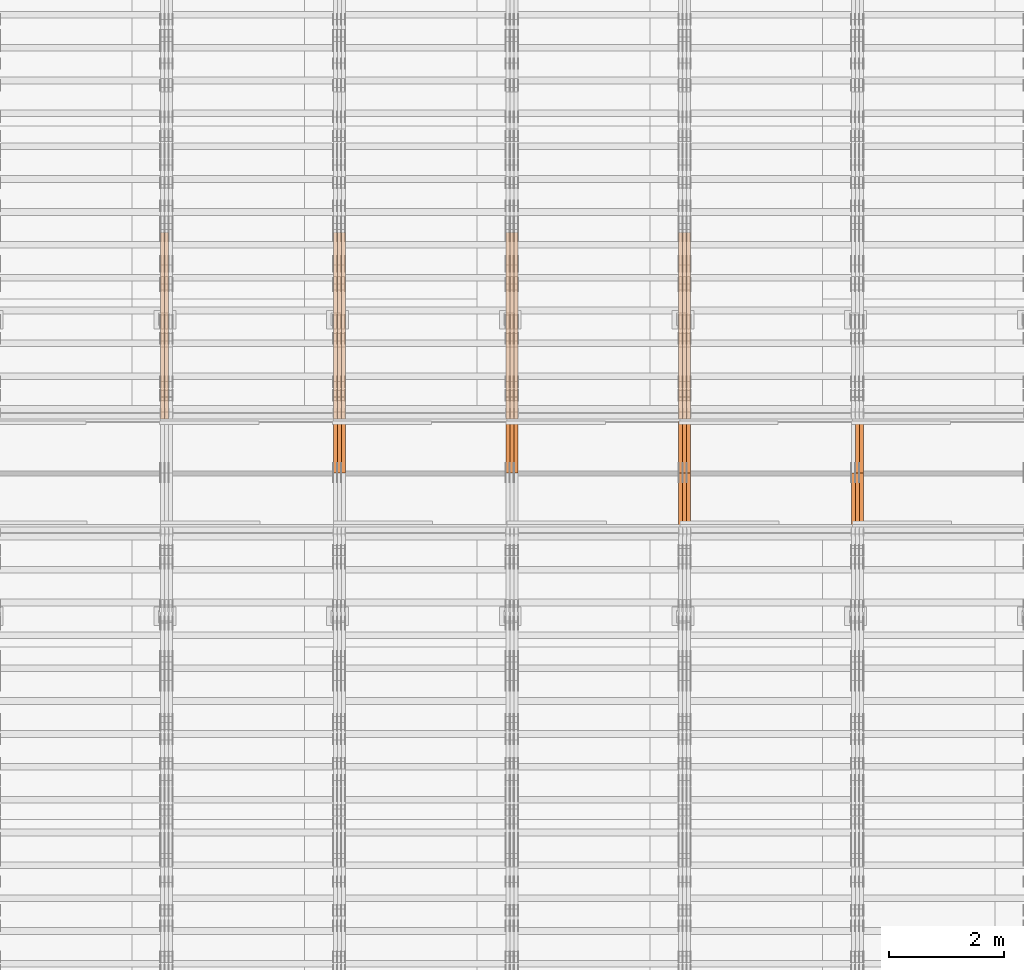
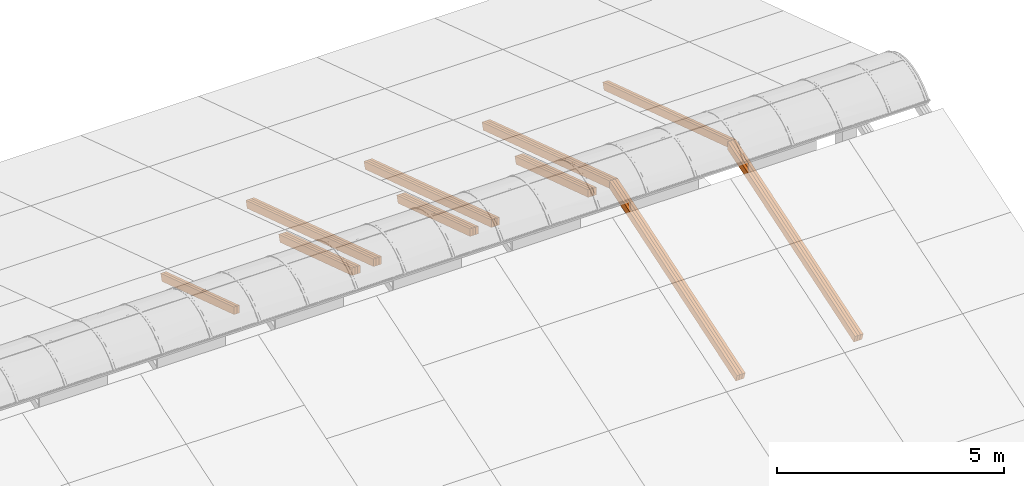
# One storey, part 27 of 385: 28 proxies.
"""IFC2X3 building model written with IfcOpenShell, lengths in millimetres."""

from ifc_helpers import new_model, entity, si_unit, converted_unit, derived_unit, direction, frame, origin, place, context, subcontext, project, spatial, polyline, outline, extrude, source, transform, mapped, material, type_object, type_shapes, element, save


model = new_model("IFC2X3")

# Units and contexts
model_context = context("Model", 3, precision=0.01, world=origin(), true_north=direction((6.12303176911189e-17, 1.0)))
body_context = subcontext(model_context, "Body", "Model", "MODEL_VIEW")
ifc_project = project(units=[si_unit("LENGTHUNIT", "METRE", prefix="MILLI"), si_unit("AREAUNIT", "SQUARE_METRE"), si_unit("VOLUMEUNIT", "CUBIC_METRE"), converted_unit("PLANEANGLEUNIT", "DEGREE", entity("IfcRatioMeasure", 0.0174532925199433), si_unit("PLANEANGLEUNIT", "RADIAN"), dimensions=[0, 0, 0, 0, 0, 0, 0]), si_unit("MASSUNIT", "GRAM", prefix="KILO"), derived_unit("MASSDENSITYUNIT", [(si_unit("MASSUNIT", "GRAM", prefix="KILO"), 1), (si_unit("LENGTHUNIT", "METRE"), -3)]), si_unit("TIMEUNIT", "SECOND"), si_unit("FREQUENCYUNIT", "HERTZ"), si_unit("THERMODYNAMICTEMPERATUREUNIT", "DEGREE_CELSIUS"), derived_unit("THERMALTRANSMITTANCEUNIT", [(si_unit("MASSUNIT", "GRAM", prefix="KILO"), 1), (si_unit("THERMODYNAMICTEMPERATUREUNIT", "KELVIN"), -1), (si_unit("TIMEUNIT", "SECOND"), -3)]), derived_unit("VOLUMETRICFLOWRATEUNIT", [(si_unit("LENGTHUNIT", "METRE"), 3), (si_unit("TIMEUNIT", "SECOND"), -1)]), si_unit("ELECTRICCURRENTUNIT", "AMPERE"), si_unit("ELECTRICVOLTAGEUNIT", "VOLT"), si_unit("POWERUNIT", "WATT"), si_unit("FORCEUNIT", "NEWTON", prefix="KILO"), si_unit("ILLUMINANCEUNIT", "LUX"), si_unit("LUMINOUSFLUXUNIT", "LUMEN"), si_unit("LUMINOUSINTENSITYUNIT", "CANDELA"), derived_unit("USERDEFINED", [(si_unit("MASSUNIT", "GRAM", prefix="KILO"), -1), (si_unit("LENGTHUNIT", "METRE"), -2), (si_unit("TIMEUNIT", "SECOND"), 3), (si_unit("LUMINOUSFLUXUNIT", "LUMEN"), 1)]), derived_unit("LINEARVELOCITYUNIT", [(si_unit("LENGTHUNIT", "METRE"), 1), (si_unit("TIMEUNIT", "SECOND"), -1)]), si_unit("PRESSUREUNIT", "PASCAL"), derived_unit("USERDEFINED", [(si_unit("LENGTHUNIT", "METRE"), -2), (si_unit("MASSUNIT", "GRAM", prefix="KILO"), 1), (si_unit("TIMEUNIT", "SECOND"), -2)])], contexts=[model_context])

# Site, building, storey
site_placement = place(None, origin())
site = spatial("IfcSite", under=ifc_project, at=site_placement, CompositionType="ELEMENT")
building_placement = place(site_placement, origin())
building = spatial("IfcBuilding", under=site, at=building_placement, CompositionType="ELEMENT")
storey_placement = place(building_placement, origin())
storey = spatial("IfcBuildingStorey", under=building, at=storey_placement, Name="Default", CompositionType="ELEMENT", Elevation=0.0)

# Proxies
ifc_material_1 = material(Name="IfcSurfaceStyle #524840")
building_element_proxy_type_1 = type_object("IfcBuildingElementProxyType", Name="T1-T1 524838", PredefinedType="NOTDEFINED", material=ifc_material_1)
shared_shape_1 = source(origin(), body_context, "Body", "SweptSolid", [
    extrude(outline(polyline([(-2970.52406677137, -97.5001477982598), (2938.84461360547, -97.5001477982598), (2938.8441722117, 97.5001477982599), (-2907.1647190458, 97.5001477982598), (-2970.52406677137, -97.5001477982598)])), frame((2938.84461360547, 97.5001477982598, 0.0), z_axis=(0.0, 0.0, 1.0), x_axis=(-1.0, 0.0, 0.0)), (0.0, 0.0, 1.0), 69.9999999999996),
])
type_shapes(building_element_proxy_type_1, [shared_shape_1])
proxy_1_placement = place(building_placement, frame((45385.0, 20279.8851854154, 2416.0025491487), z_axis=(-1.0, 0.0, 0.0), x_axis=(0.0, -0.951056516295154, 0.309016994374948)))
element("IfcBuildingElementProxy", 1, at=proxy_1_placement, inside=storey, type_object=building_element_proxy_type_1, material=ifc_material_1, Name="T1-T1", context=body_context, shape_type="MappedRepresentation", body=[
    mapped(shared_shape_1, transform((0.0, 0.0, 0.0), scale=1.0)),
])
ifc_material_2 = material(Name="IfcSurfaceStyle #524783")
building_element_proxy_type_2 = type_object("IfcBuildingElementProxyType", Name="T1-T1 524781", PredefinedType="NOTDEFINED", material=ifc_material_2)
shared_shape_2 = source(origin(), body_context, "Body", "SweptSolid", [
    extrude(outline(polyline([(-2970.52406677137, -97.5001477982598), (2938.84461360547, -97.5001477982598), (2938.8441722117, 97.5001477982599), (-2907.1647190458, 97.5001477982598), (-2970.52406677137, -97.5001477982598)])), frame((2938.84461360547, 97.5001477982598, 0.0), z_axis=(0.0, 0.0, 1.0), x_axis=(-1.0, 0.0, 0.0)), (0.0, 0.0, 1.0), 69.9999999999996),
])
type_shapes(building_element_proxy_type_2, [shared_shape_2])
proxy_2_placement = place(building_placement, frame((45315.0, 20279.8851854154, 2416.0025491487), z_axis=(-1.0, 0.0, 0.0), x_axis=(0.0, -0.951056516295154, 0.309016994374948)))
element("IfcBuildingElementProxy", 2, at=proxy_2_placement, inside=storey, type_object=building_element_proxy_type_2, material=ifc_material_2, Name="T1-T1", context=body_context, shape_type="MappedRepresentation", body=[
    mapped(shared_shape_2, transform((0.0, 0.0, 0.0), scale=1.0)),
])
ifc_material_3 = material(Name="IfcSurfaceStyle #523985")
building_element_proxy_type_3 = type_object("IfcBuildingElementProxyType", Name="T1-T1 523983", PredefinedType="NOTDEFINED", material=ifc_material_3)
shared_shape_3 = source(origin(), body_context, "Body", "SweptSolid", [
    extrude(outline(polyline([(-2938.84391703088, -97.499801613968), (2970.52383457984, -97.499801613968), (2907.16448685427, 97.499801613968), (-2938.84440440323, 97.499801613968), (-2938.84391703088, -97.499801613968)])), frame((2970.52383457984, 97.5000757893295, 0.0), z_axis=(0.0, 0.0, 1.0), x_axis=(-1.0, 0.0, 0.0)), (0.0, 0.0, 1.0), 69.9999999999996),
])
type_shapes(building_element_proxy_type_3, [shared_shape_3])
proxy_3_placement = place(building_placement, frame((45385.0, 14780.2584052475, 4242.0978974122), z_axis=(-1.0, 0.0, 0.0), x_axis=(0.0, -0.951056516295154, -0.309016994374948)))
element("IfcBuildingElementProxy", 3, at=proxy_3_placement, inside=storey, type_object=building_element_proxy_type_3, material=ifc_material_3, Name="T1-T1", context=body_context, shape_type="MappedRepresentation", body=[
    mapped(shared_shape_3, transform((0.0, 0.0, 0.0), scale=1.0)),
])
ifc_material_4 = material(Name="IfcSurfaceStyle #523928")
building_element_proxy_type_4 = type_object("IfcBuildingElementProxyType", Name="T1-T1 523926", PredefinedType="NOTDEFINED", material=ifc_material_4)
shared_shape_4 = source(origin(), body_context, "Body", "SweptSolid", [
    extrude(outline(polyline([(-2938.84391703088, -97.499801613968), (2970.52383457984, -97.499801613968), (2907.16448685427, 97.499801613968), (-2938.84440440323, 97.499801613968), (-2938.84391703088, -97.499801613968)])), frame((2970.52383457984, 97.5000757893295, 0.0), z_axis=(0.0, 0.0, 1.0), x_axis=(-1.0, 0.0, 0.0)), (0.0, 0.0, 1.0), 69.9999999999996),
])
type_shapes(building_element_proxy_type_4, [shared_shape_4])
proxy_4_placement = place(building_placement, frame((45315.0, 14780.2584052475, 4242.0978974122), z_axis=(-1.0, 0.0, 0.0), x_axis=(0.0, -0.951056516295154, -0.309016994374948)))
element("IfcBuildingElementProxy", 4, at=proxy_4_placement, inside=storey, type_object=building_element_proxy_type_4, material=ifc_material_4, Name="T1-T1", context=body_context, shape_type="MappedRepresentation", body=[
    mapped(shared_shape_4, transform((0.0, 0.0, 0.0), scale=1.0)),
])
ifc_material_5 = material(Name="IfcSurfaceStyle #523871")
building_element_proxy_type_5 = type_object("IfcBuildingElementProxyType", Name="T1-T1 523869", PredefinedType="NOTDEFINED", material=ifc_material_5)
shared_shape_5 = source(origin(), body_context, "Body", "SweptSolid", [
    extrude(outline(polyline([(-2938.84391703088, -97.499801613968), (2970.52383457984, -97.499801613968), (2907.16448685427, 97.499801613968), (-2938.84440440323, 97.499801613968), (-2938.84391703088, -97.499801613968)])), frame((2970.52383457984, 97.5000757893295, 0.0), z_axis=(0.0, 0.0, 1.0), x_axis=(-1.0, 0.0, 0.0)), (0.0, 0.0, 1.0), 69.9999999999996),
])
type_shapes(building_element_proxy_type_5, [shared_shape_5])
proxy_5_placement = place(building_placement, frame((45245.0, 14780.2584052475, 4242.0978974122), z_axis=(-1.0, 0.0, 0.0), x_axis=(0.0, -0.951056516295154, -0.309016994374948)))
element("IfcBuildingElementProxy", 5, at=proxy_5_placement, inside=storey, type_object=building_element_proxy_type_5, material=ifc_material_5, Name="T1-T1", context=body_context, shape_type="MappedRepresentation", body=[
    mapped(shared_shape_5, transform((0.0, 0.0, 0.0), scale=1.0)),
])
ifc_material_6 = material(Name="IfcSurfaceStyle #490408")
building_element_proxy_type_6 = type_object("IfcBuildingElementProxyType", Name="T1-T1 490406", PredefinedType="NOTDEFINED", material=ifc_material_6)
shared_shape_6 = source(origin(), body_context, "Body", "SweptSolid", [
    extrude(outline(polyline([(-2970.52406677137, -97.5001477982598), (2938.84461360547, -97.5001477982598), (2938.8441722117, 97.5001477982599), (-2907.1647190458, 97.5001477982598), (-2970.52406677137, -97.5001477982598)])), frame((2938.84461360547, 97.5001477982598, 0.0), z_axis=(0.0, 0.0, 1.0), x_axis=(-1.0, 0.0, 0.0)), (0.0, 0.0, 1.0), 69.9999999999996),
])
type_shapes(building_element_proxy_type_6, [shared_shape_6])
proxy_6_placement = place(building_placement, frame((42385.0, 20279.8851854154, 2416.0025491487), z_axis=(-1.0, 0.0, 0.0), x_axis=(0.0, -0.951056516295154, 0.309016994374948)))
element("IfcBuildingElementProxy", 6, at=proxy_6_placement, inside=storey, type_object=building_element_proxy_type_6, material=ifc_material_6, Name="T1-T1", context=body_context, shape_type="MappedRepresentation", body=[
    mapped(shared_shape_6, transform((0.0, 0.0, 0.0), scale=1.0)),
])
ifc_material_7 = material(Name="IfcSurfaceStyle #490351")
building_element_proxy_type_7 = type_object("IfcBuildingElementProxyType", Name="T1-T1 490349", PredefinedType="NOTDEFINED", material=ifc_material_7)
shared_shape_7 = source(origin(), body_context, "Body", "SweptSolid", [
    extrude(outline(polyline([(-2970.52406677137, -97.5001477982598), (2938.84461360547, -97.5001477982598), (2938.8441722117, 97.5001477982599), (-2907.1647190458, 97.5001477982598), (-2970.52406677137, -97.5001477982598)])), frame((2938.84461360547, 97.5001477982598, 0.0), z_axis=(0.0, 0.0, 1.0), x_axis=(-1.0, 0.0, 0.0)), (0.0, 0.0, 1.0), 69.9999999999996),
])
type_shapes(building_element_proxy_type_7, [shared_shape_7])
proxy_7_placement = place(building_placement, frame((42315.0, 20279.8851854154, 2416.0025491487), z_axis=(-1.0, 0.0, 0.0), x_axis=(0.0, -0.951056516295154, 0.309016994374948)))
element("IfcBuildingElementProxy", 7, at=proxy_7_placement, inside=storey, type_object=building_element_proxy_type_7, material=ifc_material_7, Name="T1-T1", context=body_context, shape_type="MappedRepresentation", body=[
    mapped(shared_shape_7, transform((0.0, 0.0, 0.0), scale=1.0)),
])
ifc_material_8 = material(Name="IfcSurfaceStyle #490294")
building_element_proxy_type_8 = type_object("IfcBuildingElementProxyType", Name="T1-T1 490292", PredefinedType="NOTDEFINED", material=ifc_material_8)
shared_shape_8 = source(origin(), body_context, "Body", "SweptSolid", [
    extrude(outline(polyline([(-2970.52406677137, -97.5001477982598), (2938.84461360547, -97.5001477982598), (2938.8441722117, 97.5001477982599), (-2907.1647190458, 97.5001477982598), (-2970.52406677137, -97.5001477982598)])), frame((2938.84461360547, 97.5001477982598, 0.0), z_axis=(0.0, 0.0, 1.0), x_axis=(-1.0, 0.0, 0.0)), (0.0, 0.0, 1.0), 69.9999999999996),
])
type_shapes(building_element_proxy_type_8, [shared_shape_8])
proxy_8_placement = place(building_placement, frame((42245.0, 20279.8851854154, 2416.0025491487), z_axis=(-1.0, 0.0, 0.0), x_axis=(0.0, -0.951056516295154, 0.309016994374948)))
element("IfcBuildingElementProxy", 8, at=proxy_8_placement, inside=storey, type_object=building_element_proxy_type_8, material=ifc_material_8, Name="T1-T1", context=body_context, shape_type="MappedRepresentation", body=[
    mapped(shared_shape_8, transform((0.0, 0.0, 0.0), scale=1.0)),
])
ifc_material_9 = material(Name="IfcSurfaceStyle #489553")
building_element_proxy_type_9 = type_object("IfcBuildingElementProxyType", Name="T1-T1 489551", PredefinedType="NOTDEFINED", material=ifc_material_9)
shared_shape_9 = source(origin(), body_context, "Body", "SweptSolid", [
    extrude(outline(polyline([(-2938.84391703088, -97.499801613968), (2970.52383457984, -97.499801613968), (2907.16448685427, 97.499801613968), (-2938.84440440323, 97.499801613968), (-2938.84391703088, -97.499801613968)])), frame((2970.52383457984, 97.5000757893295, 0.0), z_axis=(0.0, 0.0, 1.0), x_axis=(-1.0, 0.0, 0.0)), (0.0, 0.0, 1.0), 69.9999999999996),
])
type_shapes(building_element_proxy_type_9, [shared_shape_9])
proxy_9_placement = place(building_placement, frame((42385.0, 14780.2584052475, 4242.0978974122), z_axis=(-1.0, 0.0, 0.0), x_axis=(0.0, -0.951056516295154, -0.309016994374948)))
element("IfcBuildingElementProxy", 9, at=proxy_9_placement, inside=storey, type_object=building_element_proxy_type_9, material=ifc_material_9, Name="T1-T1", context=body_context, shape_type="MappedRepresentation", body=[
    mapped(shared_shape_9, transform((0.0, 0.0, 0.0), scale=1.0)),
])
ifc_material_10 = material(Name="IfcSurfaceStyle #489496")
building_element_proxy_type_10 = type_object("IfcBuildingElementProxyType", Name="T1-T1 489494", PredefinedType="NOTDEFINED", material=ifc_material_10)
shared_shape_10 = source(origin(), body_context, "Body", "SweptSolid", [
    extrude(outline(polyline([(-2938.84391703088, -97.499801613968), (2970.52383457984, -97.499801613968), (2907.16448685427, 97.499801613968), (-2938.84440440323, 97.499801613968), (-2938.84391703088, -97.499801613968)])), frame((2970.52383457984, 97.5000757893295, 0.0), z_axis=(0.0, 0.0, 1.0), x_axis=(-1.0, 0.0, 0.0)), (0.0, 0.0, 1.0), 69.9999999999996),
])
type_shapes(building_element_proxy_type_10, [shared_shape_10])
proxy_10_placement = place(building_placement, frame((42315.0, 14780.2584052475, 4242.0978974122), z_axis=(-1.0, 0.0, 0.0), x_axis=(0.0, -0.951056516295154, -0.309016994374948)))
element("IfcBuildingElementProxy", 10, at=proxy_10_placement, inside=storey, type_object=building_element_proxy_type_10, material=ifc_material_10, Name="T1-T1", context=body_context, shape_type="MappedRepresentation", body=[
    mapped(shared_shape_10, transform((0.0, 0.0, 0.0), scale=1.0)),
])
ifc_material_11 = material(Name="IfcSurfaceStyle #489439")
building_element_proxy_type_11 = type_object("IfcBuildingElementProxyType", Name="T1-T1 489437", PredefinedType="NOTDEFINED", material=ifc_material_11)
shared_shape_11 = source(origin(), body_context, "Body", "SweptSolid", [
    extrude(outline(polyline([(-2938.84391703088, -97.499801613968), (2970.52383457984, -97.499801613968), (2907.16448685427, 97.499801613968), (-2938.84440440323, 97.499801613968), (-2938.84391703088, -97.499801613968)])), frame((2970.52383457984, 97.5000757893295, 0.0), z_axis=(0.0, 0.0, 1.0), x_axis=(-1.0, 0.0, 0.0)), (0.0, 0.0, 1.0), 69.9999999999996),
])
type_shapes(building_element_proxy_type_11, [shared_shape_11])
proxy_11_placement = place(building_placement, frame((42245.0, 14780.2584052475, 4242.0978974122), z_axis=(-1.0, 0.0, 0.0), x_axis=(0.0, -0.951056516295154, -0.309016994374948)))
element("IfcBuildingElementProxy", 11, at=proxy_11_placement, inside=storey, type_object=building_element_proxy_type_11, material=ifc_material_11, Name="T1-T1", context=body_context, shape_type="MappedRepresentation", body=[
    mapped(shared_shape_11, transform((0.0, 0.0, 0.0), scale=1.0)),
])
ifc_material_12 = material(Name="IfcSurfaceStyle #489013")
building_element_proxy_type_12 = type_object("IfcBuildingElementProxyType", Name="T1-B3 489011", PredefinedType="NOTDEFINED", material=ifc_material_12)
shared_shape_12 = source(origin(), body_context, "Body", "SweptSolid", [
    extrude(outline(polyline([(-1715.8757175801, -97.4999653079672), (1684.19580003112, -97.4999653079672), (1684.19628740349, 97.4999653079672), (-1652.51636985451, 97.4999653079672), (-1715.8757175801, -97.4999653079672)])), frame((1684.19628740349, 97.5000561131842, 0.0), z_axis=(0.0, 0.0, 1.0), x_axis=(-1.0, 0.0, 0.0)), (0.0, 0.0, 1.0), 69.9999999999998),
])
type_shapes(building_element_proxy_type_12, [shared_shape_12])
proxy_12_placement = place(building_placement, frame((42385.0, 18833.4023156897, 2380.55582184223), z_axis=(-1.0, 0.0, 0.0), x_axis=(0.0, -0.951056516295124, 0.309016994375039)))
element("IfcBuildingElementProxy", 12, at=proxy_12_placement, inside=storey, type_object=building_element_proxy_type_12, material=ifc_material_12, Name="T1-B3", context=body_context, shape_type="MappedRepresentation", body=[
    mapped(shared_shape_12, transform((0.0, 0.0, 0.0), scale=1.0)),
])
ifc_material_13 = material(Name="IfcSurfaceStyle #488956")
building_element_proxy_type_13 = type_object("IfcBuildingElementProxyType", Name="T1-B3 488954", PredefinedType="NOTDEFINED", material=ifc_material_13)
shared_shape_13 = source(origin(), body_context, "Body", "SweptSolid", [
    extrude(outline(polyline([(-1715.8757175801, -97.4999653079672), (1684.19580003112, -97.4999653079672), (1684.19628740349, 97.4999653079672), (-1652.51636985451, 97.4999653079672), (-1715.8757175801, -97.4999653079672)])), frame((1684.19628740349, 97.5000561131842, 0.0), z_axis=(0.0, 0.0, 1.0), x_axis=(-1.0, 0.0, 0.0)), (0.0, 0.0, 1.0), 69.9999999999998),
])
type_shapes(building_element_proxy_type_13, [shared_shape_13])
proxy_13_placement = place(building_placement, frame((42315.0, 18833.4023156897, 2380.55582184223), z_axis=(-1.0, 0.0, 0.0), x_axis=(0.0, -0.951056516295124, 0.309016994375039)))
element("IfcBuildingElementProxy", 13, at=proxy_13_placement, inside=storey, type_object=building_element_proxy_type_13, material=ifc_material_13, Name="T1-B3", context=body_context, shape_type="MappedRepresentation", body=[
    mapped(shared_shape_13, transform((0.0, 0.0, 0.0), scale=1.0)),
])
ifc_material_14 = material(Name="IfcSurfaceStyle #488899")
building_element_proxy_type_14 = type_object("IfcBuildingElementProxyType", Name="T1-B3 488897", PredefinedType="NOTDEFINED", material=ifc_material_14)
shared_shape_14 = source(origin(), body_context, "Body", "SweptSolid", [
    extrude(outline(polyline([(-1715.8757175801, -97.4999653079672), (1684.19580003112, -97.4999653079672), (1684.19628740349, 97.4999653079672), (-1652.51636985451, 97.4999653079672), (-1715.8757175801, -97.4999653079672)])), frame((1684.19628740349, 97.5000561131842, 0.0), z_axis=(0.0, 0.0, 1.0), x_axis=(-1.0, 0.0, 0.0)), (0.0, 0.0, 1.0), 69.9999999999998),
])
type_shapes(building_element_proxy_type_14, [shared_shape_14])
proxy_14_placement = place(building_placement, frame((42245.0, 18833.4023156897, 2380.55582184223), z_axis=(-1.0, 0.0, 0.0), x_axis=(0.0, -0.951056516295124, 0.309016994375039)))
element("IfcBuildingElementProxy", 14, at=proxy_14_placement, inside=storey, type_object=building_element_proxy_type_14, material=ifc_material_14, Name="T1-B3", context=body_context, shape_type="MappedRepresentation", body=[
    mapped(shared_shape_14, transform((0.0, 0.0, 0.0), scale=1.0)),
])
ifc_material_15 = material(Name="IfcSurfaceStyle #455976")
building_element_proxy_type_15 = type_object("IfcBuildingElementProxyType", Name="T1-T1 455974", PredefinedType="NOTDEFINED", material=ifc_material_15)
shared_shape_15 = source(origin(), body_context, "Body", "SweptSolid", [
    extrude(outline(polyline([(-2970.52406677137, -97.5001477982598), (2938.84461360547, -97.5001477982598), (2938.8441722117, 97.5001477982599), (-2907.1647190458, 97.5001477982598), (-2970.52406677137, -97.5001477982598)])), frame((2938.84461360547, 97.5001477982598, 0.0), z_axis=(0.0, 0.0, 1.0), x_axis=(-1.0, 0.0, 0.0)), (0.0, 0.0, 1.0), 69.9999999999996),
])
type_shapes(building_element_proxy_type_15, [shared_shape_15])
proxy_15_placement = place(building_placement, frame((39385.0, 20279.8851854154, 2416.0025491487), z_axis=(-1.0, 0.0, 0.0), x_axis=(0.0, -0.951056516295154, 0.309016994374948)))
element("IfcBuildingElementProxy", 15, at=proxy_15_placement, inside=storey, type_object=building_element_proxy_type_15, material=ifc_material_15, Name="T1-T1", context=body_context, shape_type="MappedRepresentation", body=[
    mapped(shared_shape_15, transform((0.0, 0.0, 0.0), scale=1.0)),
])
ifc_material_16 = material(Name="IfcSurfaceStyle #455919")
building_element_proxy_type_16 = type_object("IfcBuildingElementProxyType", Name="T1-T1 455917", PredefinedType="NOTDEFINED", material=ifc_material_16)
shared_shape_16 = source(origin(), body_context, "Body", "SweptSolid", [
    extrude(outline(polyline([(-2970.52406677137, -97.5001477982598), (2938.84461360547, -97.5001477982598), (2938.8441722117, 97.5001477982599), (-2907.1647190458, 97.5001477982598), (-2970.52406677137, -97.5001477982598)])), frame((2938.84461360547, 97.5001477982598, 0.0), z_axis=(0.0, 0.0, 1.0), x_axis=(-1.0, 0.0, 0.0)), (0.0, 0.0, 1.0), 69.9999999999996),
])
type_shapes(building_element_proxy_type_16, [shared_shape_16])
proxy_16_placement = place(building_placement, frame((39315.0, 20279.8851854154, 2416.0025491487), z_axis=(-1.0, 0.0, 0.0), x_axis=(0.0, -0.951056516295154, 0.309016994374948)))
element("IfcBuildingElementProxy", 16, at=proxy_16_placement, inside=storey, type_object=building_element_proxy_type_16, material=ifc_material_16, Name="T1-T1", context=body_context, shape_type="MappedRepresentation", body=[
    mapped(shared_shape_16, transform((0.0, 0.0, 0.0), scale=1.0)),
])
ifc_material_17 = material(Name="IfcSurfaceStyle #455862")
building_element_proxy_type_17 = type_object("IfcBuildingElementProxyType", Name="T1-T1 455860", PredefinedType="NOTDEFINED", material=ifc_material_17)
shared_shape_17 = source(origin(), body_context, "Body", "SweptSolid", [
    extrude(outline(polyline([(-2970.52406677137, -97.5001477982598), (2938.84461360547, -97.5001477982598), (2938.8441722117, 97.5001477982599), (-2907.1647190458, 97.5001477982598), (-2970.52406677137, -97.5001477982598)])), frame((2938.84461360547, 97.5001477982598, 0.0), z_axis=(0.0, 0.0, 1.0), x_axis=(-1.0, 0.0, 0.0)), (0.0, 0.0, 1.0), 69.9999999999996),
])
type_shapes(building_element_proxy_type_17, [shared_shape_17])
proxy_17_placement = place(building_placement, frame((39245.0, 20279.8851854154, 2416.0025491487), z_axis=(-1.0, 0.0, 0.0), x_axis=(0.0, -0.951056516295154, 0.309016994374948)))
element("IfcBuildingElementProxy", 17, at=proxy_17_placement, inside=storey, type_object=building_element_proxy_type_17, material=ifc_material_17, Name="T1-T1", context=body_context, shape_type="MappedRepresentation", body=[
    mapped(shared_shape_17, transform((0.0, 0.0, 0.0), scale=1.0)),
])
ifc_material_18 = material(Name="IfcSurfaceStyle #454581")
building_element_proxy_type_18 = type_object("IfcBuildingElementProxyType", Name="T1-B3 454579", PredefinedType="NOTDEFINED", material=ifc_material_18)
shared_shape_18 = source(origin(), body_context, "Body", "SweptSolid", [
    extrude(outline(polyline([(-1715.8757175801, -97.4999653079672), (1684.19580003112, -97.4999653079672), (1684.19628740349, 97.4999653079672), (-1652.51636985451, 97.4999653079672), (-1715.8757175801, -97.4999653079672)])), frame((1684.19628740349, 97.5000561131842, 0.0), z_axis=(0.0, 0.0, 1.0), x_axis=(-1.0, 0.0, 0.0)), (0.0, 0.0, 1.0), 69.9999999999998),
])
type_shapes(building_element_proxy_type_18, [shared_shape_18])
proxy_18_placement = place(building_placement, frame((39385.0, 18833.4023156897, 2380.55582184223), z_axis=(-1.0, 0.0, 0.0), x_axis=(0.0, -0.951056516295124, 0.309016994375039)))
element("IfcBuildingElementProxy", 18, at=proxy_18_placement, inside=storey, type_object=building_element_proxy_type_18, material=ifc_material_18, Name="T1-B3", context=body_context, shape_type="MappedRepresentation", body=[
    mapped(shared_shape_18, transform((0.0, 0.0, 0.0), scale=1.0)),
])
ifc_material_19 = material(Name="IfcSurfaceStyle #454524")
building_element_proxy_type_19 = type_object("IfcBuildingElementProxyType", Name="T1-B3 454522", PredefinedType="NOTDEFINED", material=ifc_material_19)
shared_shape_19 = source(origin(), body_context, "Body", "SweptSolid", [
    extrude(outline(polyline([(-1715.8757175801, -97.4999653079672), (1684.19580003112, -97.4999653079672), (1684.19628740349, 97.4999653079672), (-1652.51636985451, 97.4999653079672), (-1715.8757175801, -97.4999653079672)])), frame((1684.19628740349, 97.5000561131842, 0.0), z_axis=(0.0, 0.0, 1.0), x_axis=(-1.0, 0.0, 0.0)), (0.0, 0.0, 1.0), 69.9999999999998),
])
type_shapes(building_element_proxy_type_19, [shared_shape_19])
proxy_19_placement = place(building_placement, frame((39315.0, 18833.4023156897, 2380.55582184223), z_axis=(-1.0, 0.0, 0.0), x_axis=(0.0, -0.951056516295124, 0.309016994375039)))
element("IfcBuildingElementProxy", 19, at=proxy_19_placement, inside=storey, type_object=building_element_proxy_type_19, material=ifc_material_19, Name="T1-B3", context=body_context, shape_type="MappedRepresentation", body=[
    mapped(shared_shape_19, transform((0.0, 0.0, 0.0), scale=1.0)),
])
ifc_material_20 = material(Name="IfcSurfaceStyle #454467")
building_element_proxy_type_20 = type_object("IfcBuildingElementProxyType", Name="T1-B3 454465", PredefinedType="NOTDEFINED", material=ifc_material_20)
shared_shape_20 = source(origin(), body_context, "Body", "SweptSolid", [
    extrude(outline(polyline([(-1715.8757175801, -97.4999653079672), (1684.19580003112, -97.4999653079672), (1684.19628740349, 97.4999653079672), (-1652.51636985451, 97.4999653079672), (-1715.8757175801, -97.4999653079672)])), frame((1684.19628740349, 97.5000561131842, 0.0), z_axis=(0.0, 0.0, 1.0), x_axis=(-1.0, 0.0, 0.0)), (0.0, 0.0, 1.0), 69.9999999999998),
])
type_shapes(building_element_proxy_type_20, [shared_shape_20])
proxy_20_placement = place(building_placement, frame((39245.0, 18833.4023156897, 2380.55582184223), z_axis=(-1.0, 0.0, 0.0), x_axis=(0.0, -0.951056516295124, 0.309016994375039)))
element("IfcBuildingElementProxy", 20, at=proxy_20_placement, inside=storey, type_object=building_element_proxy_type_20, material=ifc_material_20, Name="T1-B3", context=body_context, shape_type="MappedRepresentation", body=[
    mapped(shared_shape_20, transform((0.0, 0.0, 0.0), scale=1.0)),
])
ifc_material_21 = material(Name="IfcSurfaceStyle #421544")
building_element_proxy_type_21 = type_object("IfcBuildingElementProxyType", Name="T1-T1 421542", PredefinedType="NOTDEFINED", material=ifc_material_21)
shared_shape_21 = source(origin(), body_context, "Body", "SweptSolid", [
    extrude(outline(polyline([(-2970.52406677137, -97.5001477982598), (2938.84461360547, -97.5001477982598), (2938.8441722117, 97.5001477982599), (-2907.1647190458, 97.5001477982598), (-2970.52406677137, -97.5001477982598)])), frame((2938.84461360547, 97.5001477982598, 0.0), z_axis=(0.0, 0.0, 1.0), x_axis=(-1.0, 0.0, 0.0)), (0.0, 0.0, 1.0), 69.9999999999996),
])
type_shapes(building_element_proxy_type_21, [shared_shape_21])
proxy_21_placement = place(building_placement, frame((36385.0, 20279.8851854154, 2416.0025491487), z_axis=(-1.0, 0.0, 0.0), x_axis=(0.0, -0.951056516295154, 0.309016994374948)))
element("IfcBuildingElementProxy", 21, at=proxy_21_placement, inside=storey, type_object=building_element_proxy_type_21, material=ifc_material_21, Name="T1-T1", context=body_context, shape_type="MappedRepresentation", body=[
    mapped(shared_shape_21, transform((0.0, 0.0, 0.0), scale=1.0)),
])
ifc_material_22 = material(Name="IfcSurfaceStyle #421487")
building_element_proxy_type_22 = type_object("IfcBuildingElementProxyType", Name="T1-T1 421485", PredefinedType="NOTDEFINED", material=ifc_material_22)
shared_shape_22 = source(origin(), body_context, "Body", "SweptSolid", [
    extrude(outline(polyline([(-2970.52406677137, -97.5001477982598), (2938.84461360547, -97.5001477982598), (2938.8441722117, 97.5001477982599), (-2907.1647190458, 97.5001477982598), (-2970.52406677137, -97.5001477982598)])), frame((2938.84461360547, 97.5001477982598, 0.0), z_axis=(0.0, 0.0, 1.0), x_axis=(-1.0, 0.0, 0.0)), (0.0, 0.0, 1.0), 69.9999999999996),
])
type_shapes(building_element_proxy_type_22, [shared_shape_22])
proxy_22_placement = place(building_placement, frame((36315.0, 20279.8851854154, 2416.0025491487), z_axis=(-1.0, 0.0, 0.0), x_axis=(0.0, -0.951056516295154, 0.309016994374948)))
element("IfcBuildingElementProxy", 22, at=proxy_22_placement, inside=storey, type_object=building_element_proxy_type_22, material=ifc_material_22, Name="T1-T1", context=body_context, shape_type="MappedRepresentation", body=[
    mapped(shared_shape_22, transform((0.0, 0.0, 0.0), scale=1.0)),
])
ifc_material_23 = material(Name="IfcSurfaceStyle #421430")
building_element_proxy_type_23 = type_object("IfcBuildingElementProxyType", Name="T1-T1 421428", PredefinedType="NOTDEFINED", material=ifc_material_23)
shared_shape_23 = source(origin(), body_context, "Body", "SweptSolid", [
    extrude(outline(polyline([(-2970.52406677137, -97.5001477982598), (2938.84461360547, -97.5001477982598), (2938.8441722117, 97.5001477982599), (-2907.1647190458, 97.5001477982598), (-2970.52406677137, -97.5001477982598)])), frame((2938.84461360547, 97.5001477982598, 0.0), z_axis=(0.0, 0.0, 1.0), x_axis=(-1.0, 0.0, 0.0)), (0.0, 0.0, 1.0), 69.9999999999996),
])
type_shapes(building_element_proxy_type_23, [shared_shape_23])
proxy_23_placement = place(building_placement, frame((36245.0, 20279.8851854154, 2416.0025491487), z_axis=(-1.0, 0.0, 0.0), x_axis=(0.0, -0.951056516295154, 0.309016994374948)))
element("IfcBuildingElementProxy", 23, at=proxy_23_placement, inside=storey, type_object=building_element_proxy_type_23, material=ifc_material_23, Name="T1-T1", context=body_context, shape_type="MappedRepresentation", body=[
    mapped(shared_shape_23, transform((0.0, 0.0, 0.0), scale=1.0)),
])
ifc_material_24 = material(Name="IfcSurfaceStyle #420149")
building_element_proxy_type_24 = type_object("IfcBuildingElementProxyType", Name="T1-B3 420147", PredefinedType="NOTDEFINED", material=ifc_material_24)
shared_shape_24 = source(origin(), body_context, "Body", "SweptSolid", [
    extrude(outline(polyline([(-1715.8757175801, -97.4999653079672), (1684.19580003112, -97.4999653079672), (1684.19628740349, 97.4999653079672), (-1652.51636985451, 97.4999653079672), (-1715.8757175801, -97.4999653079672)])), frame((1684.19628740349, 97.5000561131842, 0.0), z_axis=(0.0, 0.0, 1.0), x_axis=(-1.0, 0.0, 0.0)), (0.0, 0.0, 1.0), 69.9999999999998),
])
type_shapes(building_element_proxy_type_24, [shared_shape_24])
proxy_24_placement = place(building_placement, frame((36385.0, 18833.4023156896, 2380.55582184223), z_axis=(-1.0, 0.0, 0.0), x_axis=(0.0, -0.951056516295124, 0.309016994375039)))
element("IfcBuildingElementProxy", 24, at=proxy_24_placement, inside=storey, type_object=building_element_proxy_type_24, material=ifc_material_24, Name="T1-B3", context=body_context, shape_type="MappedRepresentation", body=[
    mapped(shared_shape_24, transform((0.0, 0.0, 0.0), scale=1.0)),
])
ifc_material_25 = material(Name="IfcSurfaceStyle #420092")
building_element_proxy_type_25 = type_object("IfcBuildingElementProxyType", Name="T1-B3 420090", PredefinedType="NOTDEFINED", material=ifc_material_25)
shared_shape_25 = source(origin(), body_context, "Body", "SweptSolid", [
    extrude(outline(polyline([(-1715.8757175801, -97.4999653079672), (1684.19580003112, -97.4999653079672), (1684.19628740349, 97.4999653079672), (-1652.51636985451, 97.4999653079672), (-1715.8757175801, -97.4999653079672)])), frame((1684.19628740349, 97.5000561131842, 0.0), z_axis=(0.0, 0.0, 1.0), x_axis=(-1.0, 0.0, 0.0)), (0.0, 0.0, 1.0), 69.9999999999998),
])
type_shapes(building_element_proxy_type_25, [shared_shape_25])
proxy_25_placement = place(building_placement, frame((36315.0, 18833.4023156896, 2380.55582184223), z_axis=(-1.0, 0.0, 0.0), x_axis=(0.0, -0.951056516295124, 0.309016994375039)))
element("IfcBuildingElementProxy", 25, at=proxy_25_placement, inside=storey, type_object=building_element_proxy_type_25, material=ifc_material_25, Name="T1-B3", context=body_context, shape_type="MappedRepresentation", body=[
    mapped(shared_shape_25, transform((0.0, 0.0, 0.0), scale=1.0)),
])
ifc_material_26 = material(Name="IfcSurfaceStyle #420035")
building_element_proxy_type_26 = type_object("IfcBuildingElementProxyType", Name="T1-B3 420033", PredefinedType="NOTDEFINED", material=ifc_material_26)
shared_shape_26 = source(origin(), body_context, "Body", "SweptSolid", [
    extrude(outline(polyline([(-1715.8757175801, -97.4999653079672), (1684.19580003112, -97.4999653079672), (1684.19628740349, 97.4999653079672), (-1652.51636985451, 97.4999653079672), (-1715.8757175801, -97.4999653079672)])), frame((1684.19628740349, 97.5000561131842, 0.0), z_axis=(0.0, 0.0, 1.0), x_axis=(-1.0, 0.0, 0.0)), (0.0, 0.0, 1.0), 69.9999999999998),
])
type_shapes(building_element_proxy_type_26, [shared_shape_26])
proxy_26_placement = place(building_placement, frame((36245.0, 18833.4023156896, 2380.55582184223), z_axis=(-1.0, 0.0, 0.0), x_axis=(0.0, -0.951056516295124, 0.309016994375039)))
element("IfcBuildingElementProxy", 26, at=proxy_26_placement, inside=storey, type_object=building_element_proxy_type_26, material=ifc_material_26, Name="T1-B3", context=body_context, shape_type="MappedRepresentation", body=[
    mapped(shared_shape_26, transform((0.0, 0.0, 0.0), scale=1.0)),
])
ifc_material_27 = material(Name="IfcSurfaceStyle #385660")
building_element_proxy_type_27 = type_object("IfcBuildingElementProxyType", Name="T1-B3 385658", PredefinedType="NOTDEFINED", material=ifc_material_27)
shared_shape_27 = source(origin(), body_context, "Body", "SweptSolid", [
    extrude(outline(polyline([(-1715.8757175801, -97.4999653079672), (1684.19580003112, -97.4999653079672), (1684.19628740349, 97.4999653079672), (-1652.51636985451, 97.4999653079672), (-1715.8757175801, -97.4999653079672)])), frame((1684.19628740349, 97.5000561131842, 0.0), z_axis=(0.0, 0.0, 1.0), x_axis=(-1.0, 0.0, 0.0)), (0.0, 0.0, 1.0), 69.9999999999998),
])
type_shapes(building_element_proxy_type_27, [shared_shape_27])
proxy_27_placement = place(building_placement, frame((33315.0, 18833.4023156896, 2380.55582184223), z_axis=(-1.0, 0.0, 0.0), x_axis=(0.0, -0.951056516295124, 0.309016994375039)))
element("IfcBuildingElementProxy", 27, at=proxy_27_placement, inside=storey, type_object=building_element_proxy_type_27, material=ifc_material_27, Name="T1-B3", context=body_context, shape_type="MappedRepresentation", body=[
    mapped(shared_shape_27, transform((0.0, 0.0, 0.0), scale=1.0)),
])
ifc_material_28 = material(Name="IfcSurfaceStyle #385603")
building_element_proxy_type_28 = type_object("IfcBuildingElementProxyType", Name="T1-B3 385601", PredefinedType="NOTDEFINED", material=ifc_material_28)
shared_shape_28 = source(origin(), body_context, "Body", "SweptSolid", [
    extrude(outline(polyline([(-1715.8757175801, -97.4999653079672), (1684.19580003112, -97.4999653079672), (1684.19628740349, 97.4999653079672), (-1652.51636985451, 97.4999653079672), (-1715.8757175801, -97.4999653079672)])), frame((1684.19628740349, 97.5000561131842, 0.0), z_axis=(0.0, 0.0, 1.0), x_axis=(-1.0, 0.0, 0.0)), (0.0, 0.0, 1.0), 69.9999999999998),
])
type_shapes(building_element_proxy_type_28, [shared_shape_28])
proxy_28_placement = place(building_placement, frame((33245.0, 18833.4023156896, 2380.55582184223), z_axis=(-1.0, 0.0, 0.0), x_axis=(0.0, -0.951056516295124, 0.309016994375039)))
element("IfcBuildingElementProxy", 28, at=proxy_28_placement, inside=storey, type_object=building_element_proxy_type_28, material=ifc_material_28, Name="T1-B3", context=body_context, shape_type="MappedRepresentation", body=[
    mapped(shared_shape_28, transform((0.0, 0.0, 0.0), scale=1.0)),
])

save(model, "model.ifc")
